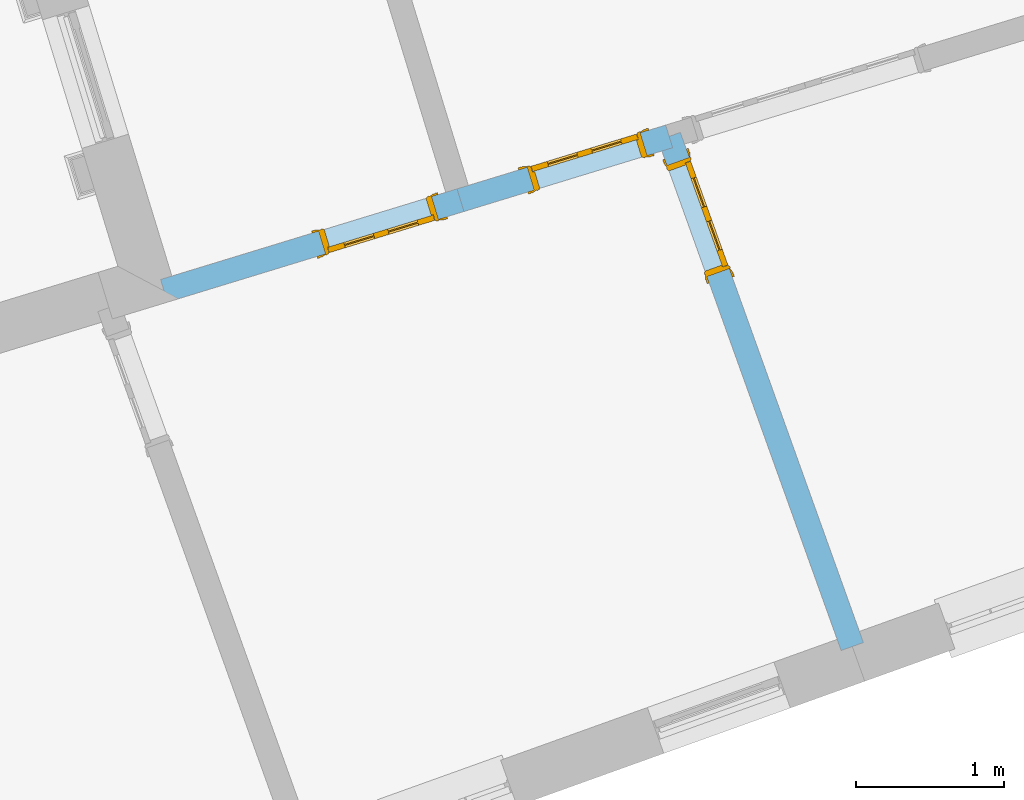
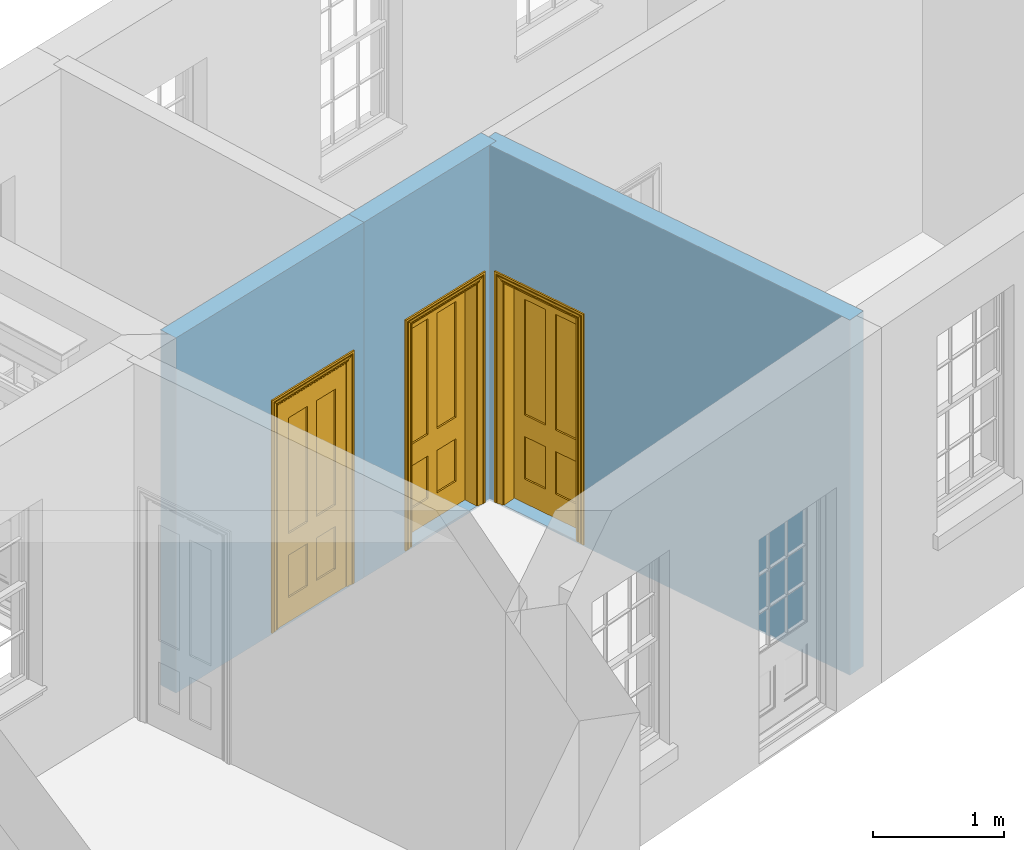
# One storey, part 7 of 10: 3 doors, 3 openings, plus 3 elements that do not belong to this part.
"""IFC2X3 building model written with IfcOpenShell, lengths in metres."""

from ifc_helpers import new_model, si_unit, frame, origin, place, context, subcontext, project, spatial, polyline, outline, extrude, faceted_brep, material, layer, layer_set, layer_usage, element, fill, save


model = new_model("IFC2X3")

# Units and contexts
model_context = context("Model", 3, world=origin())
body_context = subcontext(model_context, "Body", "Model", "MODEL_VIEW")
ifc_project = project(units=[si_unit("PLANEANGLEUNIT", "RADIAN"), si_unit("MASSUNIT", "GRAM", prefix="KILO"), si_unit("FORCEUNIT", "NEWTON", prefix="KILO"), si_unit("LENGTHUNIT", "METRE")], contexts=[model_context])

# Site, building, storey
site_placement = place(None, origin())
site = spatial("IfcSite", under=ifc_project, at=site_placement, CompositionType="ELEMENT")
building_placement = place(None, origin())
building = spatial("IfcBuilding", under=site, at=building_placement, Name="Building plot-9", CompositionType="ELEMENT")
storey_placement = place(None, frame((0.0, 0.0, 1.0)))
storey = spatial("IfcBuildingStorey", under=building, at=storey_placement, Name="Floor 0", CompositionType="ELEMENT", Elevation=1.0)

# Wall, opening, door
ifc_material = material(Name="Masonry")
ifc_layer = layer(ifc_material, 0.16, ventilated=False)
ifc_layer_set = layer_set([ifc_layer], Name="My Wall")
ifc_layer_usage = layer_usage(ifc_layer_set, "AXIS2", "NEGATIVE", 0.08)
wall_1_placement = place(storey_placement, origin())
wall_1 = element("IfcWallStandardCase", 1, at=wall_1_placement, inside=storey, material=ifc_layer_usage, Name="interior", context=body_context, shape_type="SweptSolid", body=[
    extrude(outline(polyline([(34.9703397464498, 18.7852880833866), (34.9235636395364, 18.9382978733414), (32.9172202067024, 18.3249453882046), (32.9639963136158, 18.1719355982498), (34.9703397464498, 18.7852880833866)])), origin(), (0.0, 0.0, 1.0), 3.3),
])
opening_1_placement = place(storey_placement, frame((0.0, 0.0, 0.02)))
opening_1 = element("IfcOpeningElement", 2, at=opening_1_placement, cuts=wall_1, Name="Opening", ObjectType="Opening", context=body_context, shape_type="SweptSolid", body=[
    extrude(outline(polyline([(34.7514276258372, 18.885674753064), (33.9863786760629, 18.6517942184974), (34.0331547829762, 18.4987844285425), (34.7982037327505, 18.7326649631091), (34.7514276258372, 18.885674753064)])), origin(), (0.0, 0.0, 1.0), 2.1),
])
door_1_placement = place(storey_placement, frame((34.7748156792939, 18.8091698580865, 0.02), z_axis=(0.0, 0.0, 1.0), x_axis=(-0.765048949774354, -0.233880534566598, 0.0)))
door_1 = element("IfcDoor", 3, at=door_1_placement, inside=storey, Name="circulation inside door", OverallHeight=2.1, OverallWidth=0.8, context=body_context, shape_type="Brep", held_by="IfcProductRepresentation", body=[
    faceted_brep([(0.773, 0.08, 1.895), (0.66, 0.08, 1.895), (0.66, 0.08, 2.073), (0.773, 0.08, 2.073), (0.773, 0.08, 0.82), (0.66, 0.08, 0.82), (0.45, 0.08, 1.895), (0.45, 0.08, 2.073), (0.773, 0.08, 0.62), (0.66, 0.08, 0.62), (0.66, 0.065, 0.82), (0.66, 0.065, 1.895), (0.45, 0.065, 1.895), (0.35, 0.08, 1.895), (0.35, 0.08, 2.073), (0.773, 0.08, 0.225), (0.66, 0.08, 0.225), (0.45, 0.08, 0.62), (0.45, 0.08, 0.82), (0.45, 0.065, 0.82), (0.35, 0.08, 0.82), (0.14, 0.08, 2.073), (0.14, 0.08, 1.895), (0.773, 0.08, 0.0), (0.66, 0.08, 0.0), (0.66, 0.065, 0.225), (0.66, 0.065, 0.62), (0.45, 0.065, 0.62), (0.35, 0.08, 0.62), (0.35, 0.065, 0.82), (0.35, 0.065, 1.895), (0.14, 0.065, 1.895), (0.027, 0.08, 2.073), (0.027, 0.08, 1.895), (0.773, 0.042, 0.0), (0.66, 0.042, 0.0), (0.45, 0.08, 0.0), (0.45, 0.08, 0.225), (0.45, 0.065, 0.225), (0.35, 0.08, 0.225), (0.14, 0.08, 0.82), (0.14, 0.08, 0.62), (0.14, 0.065, 0.82), (0.027, 0.08, 0.82), (0.773, 0.042, 0.225), (0.66, 0.042, 0.225), (0.45, 0.042, 0.0), (0.35, 0.08, 0.0), (0.35, 0.065, 0.225), (0.35, 0.065, 0.62), (0.14, 0.065, 0.62), (0.027, 0.08, 0.62), (0.773, 0.042, 0.62), (0.66, 0.042, 0.62), (0.45, 0.042, 0.225), (0.35, 0.042, 0.0), (0.14, 0.08, 0.225), (0.14, 0.08, 0.0), (0.14, 0.065, 0.225), (0.027, 0.08, 0.225), (0.773, 0.042, 0.82), (0.66, 0.042, 0.82), (0.66, 0.057, 0.62), (0.66, 0.057, 0.225), (0.45, 0.057, 0.225), (0.35, 0.042, 0.225), (0.14, 0.042, 0.0), (0.027, 0.08, 0.0), (0.773, 0.042, 1.895), (0.66, 0.042, 1.895), (0.45, 0.042, 0.62), (0.45, 0.042, 0.82), (0.45, 0.057, 0.62), (0.35, 0.042, 0.62), (0.14, 0.042, 0.225), (0.027, 0.042, 0.0), (0.773, 0.042, 2.073), (0.66, 0.042, 2.073), (0.66, 0.057, 1.895), (0.66, 0.057, 0.82), (0.45, 0.057, 0.82), (0.35, 0.042, 0.82), (0.35, 0.057, 0.62), (0.35, 0.057, 0.225), (0.14, 0.057, 0.225), (0.027, 0.042, 0.225), (0.45, 0.042, 1.895), (0.45, 0.042, 2.073), (0.45, 0.057, 1.895), (0.35, 0.042, 1.895), (0.14, 0.042, 0.82), (0.14, 0.042, 0.62), (0.14, 0.057, 0.62), (0.027, 0.042, 0.62), (0.35, 0.042, 2.073), (0.35, 0.057, 1.895), (0.35, 0.057, 0.82), (0.14, 0.057, 0.82), (0.027, 0.042, 0.82), (0.14, 0.042, 2.073), (0.14, 0.042, 1.895), (0.14, 0.057, 1.895), (0.027, 0.042, 1.895), (0.027, 0.042, 2.073), (0.02, 0.085, 0.0), (0.005, 0.09, 0.0), (0.005, 0.09, 2.095), (0.02, 0.085, 2.08), (0.02, 0.08, 0.0), (0.0, 0.085, 0.0), (0.0, 0.085, 2.1), (0.795, 0.09, 2.095), (0.78, 0.085, 2.08), (0.02, 0.08, 2.08), (0.0, 0.08, 0.0), (-0.032, 0.095, 0.0), (-0.032, 0.095, 2.132), (0.8, 0.085, 2.1), (0.795, 0.09, 0.0), (0.78, 0.085, 0.0), (0.78, 0.08, 2.08), (0.04, 0.04, 0.0), (0.025, 0.04, 0.0), (0.025, 0.04, 2.075), (0.04, 0.04, 2.06), (-0.04, 0.09, 0.0), (-0.04, 0.09, 2.14), (0.832, 0.095, 2.132), (0.8, 0.085, 0.0), (0.78, 0.08, 0.0), (0.8, 0.08, 0.0), (0.86, 0.08, 0.0), (0.86, 0.08, 2.16), (0.8, 0.08, 2.1), (-0.06, 0.08, 2.16), (0.0, 0.08, 2.1), (-0.06, 0.08, 0.0), (-0.04, 0.095, 0.0), (-0.04, 0.095, 2.14), (0.84, 0.09, 2.14), (0.832, 0.095, 0.0), (0.84, 0.09, 0.0), (0.86, 0.095, 0.0), (0.86, 0.095, 2.16), (-0.06, 0.095, 2.16), (-0.06, 0.095, 0.0), (0.84, 0.095, 0.0), (0.84, 0.095, 2.14), (-0.025, -0.095, 0.0), (-0.025, -0.09, 0.0), (-0.025, -0.09, 2.125), (-0.025, -0.095, 2.125), (-0.017, -0.095, 0.0), (-0.017, -0.095, 2.117), (0.825, -0.09, 2.125), (0.825, -0.095, 2.125), (0.825, -0.095, 0.0), (0.845, -0.095, 0.0), (-0.045, -0.095, 2.145), (-0.045, -0.095, 0.0), (0.845, -0.095, 2.145), (0.015, -0.085, 0.0), (0.015, -0.085, 2.085), (0.817, -0.095, 2.117), (0.825, -0.09, 0.0), (0.845, -0.08, 0.0), (0.845, -0.08, 2.145), (-0.045, -0.08, 2.145), (-0.045, -0.08, 0.0), (0.02, -0.09, 0.0), (0.02, -0.09, 2.08), (0.785, -0.085, 2.085), (0.817, -0.095, 0.0), (0.8, -0.08, 0.0), (0.8, -0.08, 2.1), (0.0, -0.08, 2.1), (0.0, -0.08, 0.0), (0.035, -0.085, 0.0), (0.035, -0.085, 2.065), (0.78, -0.09, 2.08), (0.785, -0.085, 0.0), (0.775, 0.04, 2.075), (0.76, 0.04, 2.06), (0.035, -0.08, 2.065), (0.035, -0.08, 0.0), (0.765, -0.085, 2.065), (0.78, -0.09, 0.0), (0.765, -0.08, 0.0), (0.765, -0.08, 2.065), (0.765, -0.085, 0.0), (0.04, -0.08, 2.06), (0.04, -0.08, 0.0), (0.76, -0.08, 2.06), (0.76, -0.08, 0.0), (0.76, 0.04, 0.0), (0.775, 0.04, 0.0), (0.025, 0.08, 0.0), (0.025, 0.08, 2.075), (0.775, 0.08, 0.0), (0.775, 0.08, 2.075)], [[[0, 1, 2, 3]], [[1, 0, 4, 5]], [[1, 6, 7, 2]], [[8, 9, 5, 4]], [[1, 5, 10, 11]], [[6, 1, 11, 12]], [[6, 13, 14, 7]], [[15, 16, 9, 8]], [[9, 17, 18, 5]], [[5, 18, 19, 10]], [[10, 19, 12, 11]], [[18, 6, 12, 19]], [[18, 20, 13, 6]], [[21, 14, 13, 22]], [[23, 24, 16, 15]], [[9, 16, 25, 26]], [[17, 9, 26, 27]], [[17, 28, 20, 18]], [[13, 20, 29, 30]], [[22, 13, 30, 31]], [[32, 21, 22, 33]], [[34, 35, 24, 23]], [[24, 36, 37, 16]], [[16, 37, 38, 25]], [[25, 38, 27, 26]], [[37, 17, 27, 38]], [[37, 39, 28, 17]], [[40, 20, 28, 41]], [[20, 40, 42, 29]], [[31, 30, 29, 42]], [[40, 22, 31, 42]], [[33, 22, 40, 43]], [[35, 34, 44, 45]], [[35, 46, 36, 24]], [[36, 47, 39, 37]], [[28, 39, 48, 49]], [[41, 28, 49, 50]], [[43, 40, 41, 51]], [[45, 44, 52, 53]], [[46, 35, 45, 54]], [[46, 55, 47, 36]], [[56, 39, 47, 57]], [[39, 56, 58, 48]], [[50, 49, 48, 58]], [[56, 41, 50, 58]], [[51, 41, 56, 59]], [[53, 52, 60, 61]], [[45, 53, 62, 63]], [[54, 45, 63, 64]], [[55, 46, 54, 65]], [[55, 66, 57, 47]], [[59, 56, 57, 67]], [[61, 60, 68, 69]], [[70, 53, 61, 71]], [[53, 70, 72, 62]], [[72, 64, 63, 62]], [[70, 54, 64, 72]], [[65, 54, 70, 73]], [[65, 74, 66, 55]], [[67, 57, 66, 75]], [[69, 68, 76, 77]], [[61, 69, 78, 79]], [[71, 61, 79, 80]], [[73, 70, 71, 81]], [[65, 73, 82, 83]], [[74, 65, 83, 84]], [[74, 85, 75, 66]], [[86, 69, 77, 87]], [[69, 86, 88, 78]], [[88, 80, 79, 78]], [[86, 71, 80, 88]], [[81, 71, 86, 89]], [[73, 81, 90, 91]], [[73, 91, 92, 82]], [[83, 82, 92, 84]], [[91, 74, 84, 92]], [[91, 93, 85, 74]], [[89, 86, 87, 94]], [[81, 89, 95, 96]], [[90, 81, 96, 97]], [[90, 98, 93, 91]], [[94, 99, 100, 89]], [[89, 100, 101, 95]], [[101, 97, 96, 95]], [[100, 90, 97, 101]], [[100, 102, 98, 90]], [[99, 103, 102, 100]], [[32, 103, 99, 21]], [[102, 103, 32, 33]], [[98, 102, 33, 43]], [[21, 99, 94, 14]], [[94, 87, 7, 14]], [[7, 87, 77, 2]], [[76, 3, 2, 77]], [[43, 51, 93, 98]], [[51, 59, 85, 93]], [[67, 75, 85, 59]], [[34, 23, 15, 44]], [[44, 15, 8, 52]], [[52, 8, 4, 60]], [[0, 68, 60, 4]], [[0, 3, 76, 68]], [[104, 105, 106, 107]], [[104, 108, 109, 105]], [[105, 109, 110, 106]], [[107, 106, 111, 112]], [[107, 113, 108, 104]], [[114, 109, 108]], [[109, 115, 116, 110]], [[106, 110, 117, 111]], [[112, 111, 118, 119]], [[113, 107, 112, 120]], [[121, 122, 123, 124]], [[115, 109, 114, 125]], [[115, 125, 126, 116]], [[110, 116, 127, 117]], [[111, 117, 128, 118]], [[118, 128, 129, 119]], [[120, 112, 119, 129]], [[130, 129, 128]], [[130, 131, 132, 133]], [[133, 132, 134, 135]], [[135, 134, 136, 114]], [[136, 125, 114]], [[125, 137, 138, 126]], [[116, 126, 139, 127]], [[117, 127, 140, 128]], [[141, 130, 128, 140]], [[131, 130, 141]], [[131, 142, 143, 132]], [[132, 143, 144, 134]], [[134, 144, 145, 136]], [[137, 125, 136, 145]], [[143, 142, 146]], [[143, 146, 147]], [[137, 145, 144]], [[143, 147, 138]], [[138, 137, 144]], [[143, 138, 144]], [[126, 138, 147, 139]], [[127, 139, 141, 140]], [[142, 131, 141, 146]], [[139, 147, 146, 141]], [[148, 149, 150, 151]], [[149, 152, 153, 150]], [[151, 150, 154, 155]], [[155, 156, 157]], [[158, 159, 148]], [[158, 148, 151]], [[155, 157, 160]], [[158, 151, 155]], [[155, 160, 158]], [[152, 161, 162, 153]], [[150, 153, 163, 154]], [[155, 154, 164, 156]], [[156, 164, 165, 157]], [[157, 165, 166, 160]], [[160, 166, 167, 158]], [[158, 167, 168, 159]], [[161, 169, 170, 162]], [[153, 162, 171, 163]], [[154, 163, 172, 164]], [[165, 164, 173]], [[165, 173, 174, 166]], [[166, 174, 175, 167]], [[167, 175, 176, 168]], [[169, 177, 178, 170]], [[162, 170, 179, 171]], [[163, 171, 180, 172]], [[172, 180, 173, 164]], [[124, 123, 181, 182]], [[183, 178, 177, 184]], [[170, 178, 185, 179]], [[171, 179, 186, 180]], [[187, 173, 180]], [[185, 188, 187, 189]], [[188, 185, 178, 183]], [[179, 185, 189, 186]], [[189, 187, 180, 186]], [[190, 183, 184, 191]], [[192, 188, 183, 190]], [[191, 184, 122, 121]], [[124, 190, 191, 121]], [[193, 187, 188, 192]], [[182, 192, 190, 124]], [[184, 176, 122]], [[194, 195, 187, 193]], [[192, 182, 194, 193]], [[161, 176, 184]], [[114, 108, 122, 176]], [[173, 187, 195]], [[152, 149, 176, 161]], [[169, 161, 184, 177]], [[196, 122, 108]], [[176, 175, 135, 114]], [[173, 195, 129, 130]], [[176, 149, 168]], [[123, 122, 196, 197]], [[196, 108, 113, 197]], [[175, 174, 133, 135]], [[198, 129, 195]], [[133, 174, 173, 130]], [[159, 168, 149, 148]], [[181, 123, 197, 199]], [[197, 113, 120, 199]], [[199, 120, 129, 198]], [[195, 181, 199, 198]], [[195, 194, 182, 181]]]),
])
fill(opening_1, door_1)

wall_2_placement = place(storey_placement, origin())
wall_2 = element("IfcWallStandardCase", 4, at=wall_2_placement, inside=storey, material=ifc_layer_usage, Name="interior", context=body_context, shape_type="SweptSolid", body=[
    extrude(outline(polyline([(34.9235636395364, 18.9382978733414), (34.9703397464498, 18.7852880833866), (36.3823365784182, 19.2169448734057), (36.3355604715048, 19.3699546633605), (34.9235636395364, 18.9382978733414)])), origin(), (0.0, 0.0, 1.0), 3.3),
])
opening_2_placement = place(storey_placement, frame((0.0, 0.0, 0.02)))
opening_2 = element("IfcOpeningElement", 5, at=opening_2_placement, cuts=wall_2, Name="Opening", ObjectType="Opening", context=body_context, shape_type="SweptSolid", body=[
    extrude(outline(polyline([(35.4451516149446, 18.9304412185616), (36.2102005647189, 19.1643217531282), (36.1634244578056, 19.3173315430831), (35.3983755080313, 19.0834510085165), (35.4451516149446, 18.9304412185616)])), origin(), (0.0, 0.0, 1.0), 2.1),
])
door_2_placement = place(storey_placement, frame((35.4217635614879, 19.006946113539, 0.02), z_axis=(0.0, 0.0, 1.0), x_axis=(0.765048949774361, 0.233880534566577, 0.0)))
door_2 = element("IfcDoor", 6, at=door_2_placement, inside=storey, Name="living inside door", OverallHeight=2.1, OverallWidth=0.8, context=body_context, shape_type="Brep", held_by="IfcProductRepresentation", body=[
    faceted_brep([(0.773, 0.08, 1.895), (0.66, 0.08, 1.895), (0.66, 0.08, 2.073), (0.773, 0.08, 2.073), (0.773, 0.08, 0.82), (0.66, 0.08, 0.82), (0.45, 0.08, 1.895), (0.45, 0.08, 2.073), (0.773, 0.08, 0.62), (0.66, 0.08, 0.62), (0.66, 0.065, 0.82), (0.66, 0.065, 1.895), (0.45, 0.065, 1.895), (0.35, 0.08, 1.895), (0.35, 0.08, 2.073), (0.773, 0.08, 0.225), (0.66, 0.08, 0.225), (0.45, 0.08, 0.62), (0.45, 0.08, 0.82), (0.45, 0.065, 0.82), (0.35, 0.08, 0.82), (0.14, 0.08, 2.073), (0.14, 0.08, 1.895), (0.773, 0.08, 0.0), (0.66, 0.08, 0.0), (0.66, 0.065, 0.225), (0.66, 0.065, 0.62), (0.45, 0.065, 0.62), (0.35, 0.08, 0.62), (0.35, 0.065, 0.82), (0.35, 0.065, 1.895), (0.14, 0.065, 1.895), (0.027, 0.08, 2.073), (0.027, 0.08, 1.895), (0.773, 0.042, 0.0), (0.66, 0.042, 0.0), (0.45, 0.08, 0.0), (0.45, 0.08, 0.225), (0.45, 0.065, 0.225), (0.35, 0.08, 0.225), (0.14, 0.08, 0.82), (0.14, 0.08, 0.62), (0.14, 0.065, 0.82), (0.027, 0.08, 0.82), (0.773, 0.042, 0.225), (0.66, 0.042, 0.225), (0.45, 0.042, 0.0), (0.35, 0.08, 0.0), (0.35, 0.065, 0.225), (0.35, 0.065, 0.62), (0.14, 0.065, 0.62), (0.027, 0.08, 0.62), (0.773, 0.042, 0.62), (0.66, 0.042, 0.62), (0.45, 0.042, 0.225), (0.35, 0.042, 0.0), (0.14, 0.08, 0.225), (0.14, 0.08, 0.0), (0.14, 0.065, 0.225), (0.027, 0.08, 0.225), (0.773, 0.042, 0.82), (0.66, 0.042, 0.82), (0.66, 0.057, 0.62), (0.66, 0.057, 0.225), (0.45, 0.057, 0.225), (0.35, 0.042, 0.225), (0.14, 0.042, 0.0), (0.027, 0.08, 0.0), (0.773, 0.042, 1.895), (0.66, 0.042, 1.895), (0.45, 0.042, 0.62), (0.45, 0.042, 0.82), (0.45, 0.057, 0.62), (0.35, 0.042, 0.62), (0.14, 0.042, 0.225), (0.027, 0.042, 0.0), (0.773, 0.042, 2.073), (0.66, 0.042, 2.073), (0.66, 0.057, 1.895), (0.66, 0.057, 0.82), (0.45, 0.057, 0.82), (0.35, 0.042, 0.82), (0.35, 0.057, 0.62), (0.35, 0.057, 0.225), (0.14, 0.057, 0.225), (0.027, 0.042, 0.225), (0.45, 0.042, 1.895), (0.45, 0.042, 2.073), (0.45, 0.057, 1.895), (0.35, 0.042, 1.895), (0.14, 0.042, 0.82), (0.14, 0.042, 0.62), (0.14, 0.057, 0.62), (0.027, 0.042, 0.62), (0.35, 0.042, 2.073), (0.35, 0.057, 1.895), (0.35, 0.057, 0.82), (0.14, 0.057, 0.82), (0.027, 0.042, 0.82), (0.14, 0.042, 2.073), (0.14, 0.042, 1.895), (0.14, 0.057, 1.895), (0.027, 0.042, 1.895), (0.027, 0.042, 2.073), (0.02, 0.085, 0.0), (0.005, 0.09, 0.0), (0.005, 0.09, 2.095), (0.02, 0.085, 2.08), (0.02, 0.08, 0.0), (0.0, 0.085, 0.0), (0.0, 0.085, 2.1), (0.795, 0.09, 2.095), (0.78, 0.085, 2.08), (0.02, 0.08, 2.08), (0.0, 0.08, 0.0), (-0.032, 0.095, 0.0), (-0.032, 0.095, 2.132), (0.8, 0.085, 2.1), (0.795, 0.09, 0.0), (0.78, 0.085, 0.0), (0.78, 0.08, 2.08), (0.04, 0.04, 0.0), (0.025, 0.04, 0.0), (0.025, 0.04, 2.075), (0.04, 0.04, 2.06), (-0.04, 0.09, 0.0), (-0.04, 0.09, 2.14), (0.832, 0.095, 2.132), (0.8, 0.085, 0.0), (0.78, 0.08, 0.0), (0.8, 0.08, 0.0), (0.86, 0.08, 0.0), (0.86, 0.08, 2.16), (0.8, 0.08, 2.1), (-0.06, 0.08, 2.16), (0.0, 0.08, 2.1), (-0.06, 0.08, 0.0), (-0.04, 0.095, 0.0), (-0.04, 0.095, 2.14), (0.84, 0.09, 2.14), (0.832, 0.095, 0.0), (0.84, 0.09, 0.0), (0.86, 0.095, 0.0), (0.86, 0.095, 2.16), (-0.06, 0.095, 2.16), (-0.06, 0.095, 0.0), (0.84, 0.095, 0.0), (0.84, 0.095, 2.14), (-0.025, -0.095, 0.0), (-0.025, -0.09, 0.0), (-0.025, -0.09, 2.125), (-0.025, -0.095, 2.125), (-0.017, -0.095, 0.0), (-0.017, -0.095, 2.117), (0.825, -0.09, 2.125), (0.825, -0.095, 2.125), (0.825, -0.095, 0.0), (0.845, -0.095, 0.0), (-0.045, -0.095, 2.145), (-0.045, -0.095, 0.0), (0.845, -0.095, 2.145), (0.015, -0.085, 0.0), (0.015, -0.085, 2.085), (0.817, -0.095, 2.117), (0.825, -0.09, 0.0), (0.845, -0.08, 0.0), (0.845, -0.08, 2.145), (-0.045, -0.08, 2.145), (-0.045, -0.08, 0.0), (0.02, -0.09, 0.0), (0.02, -0.09, 2.08), (0.785, -0.085, 2.085), (0.817, -0.095, 0.0), (0.8, -0.08, 0.0), (0.8, -0.08, 2.1), (0.0, -0.08, 2.1), (0.0, -0.08, 0.0), (0.035, -0.085, 0.0), (0.035, -0.085, 2.065), (0.78, -0.09, 2.08), (0.785, -0.085, 0.0), (0.775, 0.04, 2.075), (0.76, 0.04, 2.06), (0.035, -0.08, 2.065), (0.035, -0.08, 0.0), (0.765, -0.085, 2.065), (0.78, -0.09, 0.0), (0.765, -0.08, 0.0), (0.765, -0.08, 2.065), (0.765, -0.085, 0.0), (0.04, -0.08, 2.06), (0.04, -0.08, 0.0), (0.76, -0.08, 2.06), (0.76, -0.08, 0.0), (0.76, 0.04, 0.0), (0.775, 0.04, 0.0), (0.025, 0.08, 0.0), (0.025, 0.08, 2.075), (0.775, 0.08, 0.0), (0.775, 0.08, 2.075)], [[[0, 1, 2, 3]], [[1, 0, 4, 5]], [[1, 6, 7, 2]], [[8, 9, 5, 4]], [[1, 5, 10, 11]], [[6, 1, 11, 12]], [[6, 13, 14, 7]], [[15, 16, 9, 8]], [[9, 17, 18, 5]], [[5, 18, 19, 10]], [[10, 19, 12, 11]], [[18, 6, 12, 19]], [[18, 20, 13, 6]], [[21, 14, 13, 22]], [[23, 24, 16, 15]], [[9, 16, 25, 26]], [[17, 9, 26, 27]], [[17, 28, 20, 18]], [[13, 20, 29, 30]], [[22, 13, 30, 31]], [[32, 21, 22, 33]], [[34, 35, 24, 23]], [[24, 36, 37, 16]], [[16, 37, 38, 25]], [[25, 38, 27, 26]], [[37, 17, 27, 38]], [[37, 39, 28, 17]], [[40, 20, 28, 41]], [[20, 40, 42, 29]], [[31, 30, 29, 42]], [[40, 22, 31, 42]], [[33, 22, 40, 43]], [[35, 34, 44, 45]], [[35, 46, 36, 24]], [[36, 47, 39, 37]], [[28, 39, 48, 49]], [[41, 28, 49, 50]], [[43, 40, 41, 51]], [[45, 44, 52, 53]], [[46, 35, 45, 54]], [[46, 55, 47, 36]], [[56, 39, 47, 57]], [[39, 56, 58, 48]], [[50, 49, 48, 58]], [[56, 41, 50, 58]], [[51, 41, 56, 59]], [[53, 52, 60, 61]], [[45, 53, 62, 63]], [[54, 45, 63, 64]], [[55, 46, 54, 65]], [[55, 66, 57, 47]], [[59, 56, 57, 67]], [[61, 60, 68, 69]], [[70, 53, 61, 71]], [[53, 70, 72, 62]], [[72, 64, 63, 62]], [[70, 54, 64, 72]], [[65, 54, 70, 73]], [[65, 74, 66, 55]], [[67, 57, 66, 75]], [[69, 68, 76, 77]], [[61, 69, 78, 79]], [[71, 61, 79, 80]], [[73, 70, 71, 81]], [[65, 73, 82, 83]], [[74, 65, 83, 84]], [[74, 85, 75, 66]], [[86, 69, 77, 87]], [[69, 86, 88, 78]], [[88, 80, 79, 78]], [[86, 71, 80, 88]], [[81, 71, 86, 89]], [[73, 81, 90, 91]], [[73, 91, 92, 82]], [[83, 82, 92, 84]], [[91, 74, 84, 92]], [[91, 93, 85, 74]], [[89, 86, 87, 94]], [[81, 89, 95, 96]], [[90, 81, 96, 97]], [[90, 98, 93, 91]], [[94, 99, 100, 89]], [[89, 100, 101, 95]], [[101, 97, 96, 95]], [[100, 90, 97, 101]], [[100, 102, 98, 90]], [[99, 103, 102, 100]], [[32, 103, 99, 21]], [[102, 103, 32, 33]], [[98, 102, 33, 43]], [[21, 99, 94, 14]], [[94, 87, 7, 14]], [[7, 87, 77, 2]], [[76, 3, 2, 77]], [[43, 51, 93, 98]], [[51, 59, 85, 93]], [[67, 75, 85, 59]], [[34, 23, 15, 44]], [[44, 15, 8, 52]], [[52, 8, 4, 60]], [[0, 68, 60, 4]], [[0, 3, 76, 68]], [[104, 105, 106, 107]], [[104, 108, 109, 105]], [[105, 109, 110, 106]], [[107, 106, 111, 112]], [[107, 113, 108, 104]], [[114, 109, 108]], [[109, 115, 116, 110]], [[106, 110, 117, 111]], [[112, 111, 118, 119]], [[113, 107, 112, 120]], [[121, 122, 123, 124]], [[115, 109, 114, 125]], [[115, 125, 126, 116]], [[110, 116, 127, 117]], [[111, 117, 128, 118]], [[118, 128, 129, 119]], [[120, 112, 119, 129]], [[130, 129, 128]], [[130, 131, 132, 133]], [[133, 132, 134, 135]], [[135, 134, 136, 114]], [[136, 125, 114]], [[125, 137, 138, 126]], [[116, 126, 139, 127]], [[117, 127, 140, 128]], [[141, 130, 128, 140]], [[131, 130, 141]], [[131, 142, 143, 132]], [[132, 143, 144, 134]], [[134, 144, 145, 136]], [[137, 125, 136, 145]], [[143, 142, 146]], [[143, 146, 147]], [[137, 145, 144]], [[143, 147, 138]], [[138, 137, 144]], [[143, 138, 144]], [[126, 138, 147, 139]], [[127, 139, 141, 140]], [[142, 131, 141, 146]], [[139, 147, 146, 141]], [[148, 149, 150, 151]], [[149, 152, 153, 150]], [[151, 150, 154, 155]], [[155, 156, 157]], [[158, 159, 148]], [[158, 148, 151]], [[155, 157, 160]], [[158, 151, 155]], [[155, 160, 158]], [[152, 161, 162, 153]], [[150, 153, 163, 154]], [[155, 154, 164, 156]], [[156, 164, 165, 157]], [[157, 165, 166, 160]], [[160, 166, 167, 158]], [[158, 167, 168, 159]], [[161, 169, 170, 162]], [[153, 162, 171, 163]], [[154, 163, 172, 164]], [[165, 164, 173]], [[165, 173, 174, 166]], [[166, 174, 175, 167]], [[167, 175, 176, 168]], [[169, 177, 178, 170]], [[162, 170, 179, 171]], [[163, 171, 180, 172]], [[172, 180, 173, 164]], [[124, 123, 181, 182]], [[183, 178, 177, 184]], [[170, 178, 185, 179]], [[171, 179, 186, 180]], [[187, 173, 180]], [[185, 188, 187, 189]], [[188, 185, 178, 183]], [[179, 185, 189, 186]], [[189, 187, 180, 186]], [[190, 183, 184, 191]], [[192, 188, 183, 190]], [[191, 184, 122, 121]], [[124, 190, 191, 121]], [[193, 187, 188, 192]], [[182, 192, 190, 124]], [[184, 176, 122]], [[194, 195, 187, 193]], [[192, 182, 194, 193]], [[161, 176, 184]], [[114, 108, 122, 176]], [[173, 187, 195]], [[152, 149, 176, 161]], [[169, 161, 184, 177]], [[196, 122, 108]], [[176, 175, 135, 114]], [[173, 195, 129, 130]], [[176, 149, 168]], [[123, 122, 196, 197]], [[196, 108, 113, 197]], [[175, 174, 133, 135]], [[198, 129, 195]], [[133, 174, 173, 130]], [[159, 168, 149, 148]], [[181, 123, 197, 199]], [[197, 113, 120, 199]], [[199, 120, 129, 198]], [[195, 181, 199, 198]], [[195, 194, 182, 181]]]),
])
fill(opening_2, door_2)

wall_3_placement = place(storey_placement, origin())
wall_3 = element("IfcWallStandardCase", 7, at=wall_3_placement, inside=storey, material=ifc_layer_usage, Name="interior", context=body_context, shape_type="SweptSolid", body=[
    extrude(outline(polyline([(36.4342442893172, 19.3204784174447), (36.2836527606058, 19.2664211193215), (37.5228374656723, 15.8143299943324), (37.6734289943837, 15.8683872924556), (36.4342442893172, 19.3204784174447)])), origin(), (0.0, 0.0, 1.0), 3.3),
])
opening_3_placement = place(storey_placement, frame((0.0, 0.0, 0.02)))
opening_3 = element("IfcOpeningElement", 8, at=opening_3_placement, cuts=wall_3, Name="Opening", ObjectType="Opening", context=body_context, shape_type="SweptSolid", body=[
    extrude(outline(polyline([(36.3444672209943, 19.0970056495212), (36.6147537116099, 18.3440480059644), (36.7653452403213, 18.3981053040875), (36.4950587497057, 19.1510629476444), (36.3444672209943, 19.0970056495212)])), origin(), (0.0, 0.0, 1.0), 2.1),
])
door_3_placement = place(storey_placement, frame((36.41976298535, 19.1240342985828, 0.02), z_axis=(0.0, 0.0, 1.0), x_axis=(0.270286490615604, -0.752957643556858, 0.0)))
door_3 = element("IfcDoor", 9, at=door_3_placement, inside=storey, Name="kitchen inside door", OverallHeight=2.1, OverallWidth=0.8, context=body_context, shape_type="Brep", held_by="IfcProductRepresentation", body=[
    faceted_brep([(0.773, 0.08, 1.895), (0.66, 0.08, 1.895), (0.66, 0.08, 2.073), (0.773, 0.08, 2.073), (0.773, 0.08, 0.82), (0.66, 0.08, 0.82), (0.45, 0.08, 1.895), (0.45, 0.08, 2.073), (0.773, 0.08, 0.62), (0.66, 0.08, 0.62), (0.66, 0.065, 0.82), (0.66, 0.065, 1.895), (0.45, 0.065, 1.895), (0.35, 0.08, 1.895), (0.35, 0.08, 2.073), (0.773, 0.08, 0.225), (0.66, 0.08, 0.225), (0.45, 0.08, 0.62), (0.45, 0.08, 0.82), (0.45, 0.065, 0.82), (0.35, 0.08, 0.82), (0.14, 0.08, 2.073), (0.14, 0.08, 1.895), (0.773, 0.08, 0.0), (0.66, 0.08, 0.0), (0.66, 0.065, 0.225), (0.66, 0.065, 0.62), (0.45, 0.065, 0.62), (0.35, 0.08, 0.62), (0.35, 0.065, 0.82), (0.35, 0.065, 1.895), (0.14, 0.065, 1.895), (0.027, 0.08, 2.073), (0.027, 0.08, 1.895), (0.773, 0.042, 0.0), (0.66, 0.042, 0.0), (0.45, 0.08, 0.0), (0.45, 0.08, 0.225), (0.45, 0.065, 0.225), (0.35, 0.08, 0.225), (0.14, 0.08, 0.82), (0.14, 0.08, 0.62), (0.14, 0.065, 0.82), (0.027, 0.08, 0.82), (0.773, 0.042, 0.225), (0.66, 0.042, 0.225), (0.45, 0.042, 0.0), (0.35, 0.08, 0.0), (0.35, 0.065, 0.225), (0.35, 0.065, 0.62), (0.14, 0.065, 0.62), (0.027, 0.08, 0.62), (0.773, 0.042, 0.62), (0.66, 0.042, 0.62), (0.45, 0.042, 0.225), (0.35, 0.042, 0.0), (0.14, 0.08, 0.225), (0.14, 0.08, 0.0), (0.14, 0.065, 0.225), (0.027, 0.08, 0.225), (0.773, 0.042, 0.82), (0.66, 0.042, 0.82), (0.66, 0.057, 0.62), (0.66, 0.057, 0.225), (0.45, 0.057, 0.225), (0.35, 0.042, 0.225), (0.14, 0.042, 0.0), (0.027, 0.08, 0.0), (0.773, 0.042, 1.895), (0.66, 0.042, 1.895), (0.45, 0.042, 0.62), (0.45, 0.042, 0.82), (0.45, 0.057, 0.62), (0.35, 0.042, 0.62), (0.14, 0.042, 0.225), (0.027, 0.042, 0.0), (0.773, 0.042, 2.073), (0.66, 0.042, 2.073), (0.66, 0.057, 1.895), (0.66, 0.057, 0.82), (0.45, 0.057, 0.82), (0.35, 0.042, 0.82), (0.35, 0.057, 0.62), (0.35, 0.057, 0.225), (0.14, 0.057, 0.225), (0.027, 0.042, 0.225), (0.45, 0.042, 1.895), (0.45, 0.042, 2.073), (0.45, 0.057, 1.895), (0.35, 0.042, 1.895), (0.14, 0.042, 0.82), (0.14, 0.042, 0.62), (0.14, 0.057, 0.62), (0.027, 0.042, 0.62), (0.35, 0.042, 2.073), (0.35, 0.057, 1.895), (0.35, 0.057, 0.82), (0.14, 0.057, 0.82), (0.027, 0.042, 0.82), (0.14, 0.042, 2.073), (0.14, 0.042, 1.895), (0.14, 0.057, 1.895), (0.027, 0.042, 1.895), (0.027, 0.042, 2.073), (0.02, 0.085, 0.0), (0.005, 0.09, 0.0), (0.005, 0.09, 2.095), (0.02, 0.085, 2.08), (0.02, 0.08, 0.0), (0.0, 0.085, 0.0), (0.0, 0.085, 2.1), (0.795, 0.09, 2.095), (0.78, 0.085, 2.08), (0.02, 0.08, 2.08), (0.0, 0.08, 0.0), (-0.032, 0.095, 0.0), (-0.032, 0.095, 2.132), (0.8, 0.085, 2.1), (0.795, 0.09, 0.0), (0.78, 0.085, 0.0), (0.78, 0.08, 2.08), (0.04, 0.04, 0.0), (0.025, 0.04, 0.0), (0.025, 0.04, 2.075), (0.04, 0.04, 2.06), (-0.04, 0.09, 0.0), (-0.04, 0.09, 2.14), (0.832, 0.095, 2.132), (0.8, 0.085, 0.0), (0.78, 0.08, 0.0), (0.8, 0.08, 0.0), (0.86, 0.08, 0.0), (0.86, 0.08, 2.16), (0.8, 0.08, 2.1), (-0.06, 0.08, 2.16), (0.0, 0.08, 2.1), (-0.06, 0.08, 0.0), (-0.04, 0.095, 0.0), (-0.04, 0.095, 2.14), (0.84, 0.09, 2.14), (0.832, 0.095, 0.0), (0.84, 0.09, 0.0), (0.86, 0.095, 0.0), (0.86, 0.095, 2.16), (-0.06, 0.095, 2.16), (-0.06, 0.095, 0.0), (0.84, 0.095, 0.0), (0.84, 0.095, 2.14), (-0.025, -0.095, 0.0), (-0.025, -0.09, 0.0), (-0.025, -0.09, 2.125), (-0.025, -0.095, 2.125), (-0.017, -0.095, 0.0), (-0.017, -0.095, 2.117), (0.825, -0.09, 2.125), (0.825, -0.095, 2.125), (0.825, -0.095, 0.0), (0.845, -0.095, 0.0), (-0.045, -0.095, 2.145), (-0.045, -0.095, 0.0), (0.845, -0.095, 2.145), (0.015, -0.085, 0.0), (0.015, -0.085, 2.085), (0.817, -0.095, 2.117), (0.825, -0.09, 0.0), (0.845, -0.08, 0.0), (0.845, -0.08, 2.145), (-0.045, -0.08, 2.145), (-0.045, -0.08, 0.0), (0.02, -0.09, 0.0), (0.02, -0.09, 2.08), (0.785, -0.085, 2.085), (0.817, -0.095, 0.0), (0.8, -0.08, 0.0), (0.8, -0.08, 2.1), (0.0, -0.08, 2.1), (0.0, -0.08, 0.0), (0.035, -0.085, 0.0), (0.035, -0.085, 2.065), (0.78, -0.09, 2.08), (0.785, -0.085, 0.0), (0.775, 0.04, 2.075), (0.76, 0.04, 2.06), (0.035, -0.08, 2.065), (0.035, -0.08, 0.0), (0.765, -0.085, 2.065), (0.78, -0.09, 0.0), (0.765, -0.08, 0.0), (0.765, -0.08, 2.065), (0.765, -0.085, 0.0), (0.04, -0.08, 2.06), (0.04, -0.08, 0.0), (0.76, -0.08, 2.06), (0.76, -0.08, 0.0), (0.76, 0.04, 0.0), (0.775, 0.04, 0.0), (0.025, 0.08, 0.0), (0.025, 0.08, 2.075), (0.775, 0.08, 0.0), (0.775, 0.08, 2.075)], [[[0, 1, 2, 3]], [[1, 0, 4, 5]], [[1, 6, 7, 2]], [[8, 9, 5, 4]], [[1, 5, 10, 11]], [[6, 1, 11, 12]], [[6, 13, 14, 7]], [[15, 16, 9, 8]], [[9, 17, 18, 5]], [[5, 18, 19, 10]], [[10, 19, 12, 11]], [[18, 6, 12, 19]], [[18, 20, 13, 6]], [[21, 14, 13, 22]], [[23, 24, 16, 15]], [[9, 16, 25, 26]], [[17, 9, 26, 27]], [[17, 28, 20, 18]], [[13, 20, 29, 30]], [[22, 13, 30, 31]], [[32, 21, 22, 33]], [[34, 35, 24, 23]], [[24, 36, 37, 16]], [[16, 37, 38, 25]], [[25, 38, 27, 26]], [[37, 17, 27, 38]], [[37, 39, 28, 17]], [[40, 20, 28, 41]], [[20, 40, 42, 29]], [[31, 30, 29, 42]], [[40, 22, 31, 42]], [[33, 22, 40, 43]], [[35, 34, 44, 45]], [[35, 46, 36, 24]], [[36, 47, 39, 37]], [[28, 39, 48, 49]], [[41, 28, 49, 50]], [[43, 40, 41, 51]], [[45, 44, 52, 53]], [[46, 35, 45, 54]], [[46, 55, 47, 36]], [[56, 39, 47, 57]], [[39, 56, 58, 48]], [[50, 49, 48, 58]], [[56, 41, 50, 58]], [[51, 41, 56, 59]], [[53, 52, 60, 61]], [[45, 53, 62, 63]], [[54, 45, 63, 64]], [[55, 46, 54, 65]], [[55, 66, 57, 47]], [[59, 56, 57, 67]], [[61, 60, 68, 69]], [[70, 53, 61, 71]], [[53, 70, 72, 62]], [[72, 64, 63, 62]], [[70, 54, 64, 72]], [[65, 54, 70, 73]], [[65, 74, 66, 55]], [[67, 57, 66, 75]], [[69, 68, 76, 77]], [[61, 69, 78, 79]], [[71, 61, 79, 80]], [[73, 70, 71, 81]], [[65, 73, 82, 83]], [[74, 65, 83, 84]], [[74, 85, 75, 66]], [[86, 69, 77, 87]], [[69, 86, 88, 78]], [[88, 80, 79, 78]], [[86, 71, 80, 88]], [[81, 71, 86, 89]], [[73, 81, 90, 91]], [[73, 91, 92, 82]], [[83, 82, 92, 84]], [[91, 74, 84, 92]], [[91, 93, 85, 74]], [[89, 86, 87, 94]], [[81, 89, 95, 96]], [[90, 81, 96, 97]], [[90, 98, 93, 91]], [[94, 99, 100, 89]], [[89, 100, 101, 95]], [[101, 97, 96, 95]], [[100, 90, 97, 101]], [[100, 102, 98, 90]], [[99, 103, 102, 100]], [[32, 103, 99, 21]], [[102, 103, 32, 33]], [[98, 102, 33, 43]], [[21, 99, 94, 14]], [[94, 87, 7, 14]], [[7, 87, 77, 2]], [[76, 3, 2, 77]], [[43, 51, 93, 98]], [[51, 59, 85, 93]], [[67, 75, 85, 59]], [[34, 23, 15, 44]], [[44, 15, 8, 52]], [[52, 8, 4, 60]], [[0, 68, 60, 4]], [[0, 3, 76, 68]], [[104, 105, 106, 107]], [[104, 108, 109, 105]], [[105, 109, 110, 106]], [[107, 106, 111, 112]], [[107, 113, 108, 104]], [[114, 109, 108]], [[109, 115, 116, 110]], [[106, 110, 117, 111]], [[112, 111, 118, 119]], [[113, 107, 112, 120]], [[121, 122, 123, 124]], [[115, 109, 114, 125]], [[115, 125, 126, 116]], [[110, 116, 127, 117]], [[111, 117, 128, 118]], [[118, 128, 129, 119]], [[120, 112, 119, 129]], [[130, 129, 128]], [[130, 131, 132, 133]], [[133, 132, 134, 135]], [[135, 134, 136, 114]], [[136, 125, 114]], [[125, 137, 138, 126]], [[116, 126, 139, 127]], [[117, 127, 140, 128]], [[141, 130, 128, 140]], [[131, 130, 141]], [[131, 142, 143, 132]], [[132, 143, 144, 134]], [[134, 144, 145, 136]], [[137, 125, 136, 145]], [[143, 142, 146]], [[143, 146, 147]], [[137, 145, 144]], [[143, 147, 138]], [[138, 137, 144]], [[143, 138, 144]], [[126, 138, 147, 139]], [[127, 139, 141, 140]], [[142, 131, 141, 146]], [[139, 147, 146, 141]], [[148, 149, 150, 151]], [[149, 152, 153, 150]], [[151, 150, 154, 155]], [[155, 156, 157]], [[158, 159, 148]], [[158, 148, 151]], [[155, 157, 160]], [[158, 151, 155]], [[155, 160, 158]], [[152, 161, 162, 153]], [[150, 153, 163, 154]], [[155, 154, 164, 156]], [[156, 164, 165, 157]], [[157, 165, 166, 160]], [[160, 166, 167, 158]], [[158, 167, 168, 159]], [[161, 169, 170, 162]], [[153, 162, 171, 163]], [[154, 163, 172, 164]], [[165, 164, 173]], [[165, 173, 174, 166]], [[166, 174, 175, 167]], [[167, 175, 176, 168]], [[169, 177, 178, 170]], [[162, 170, 179, 171]], [[163, 171, 180, 172]], [[172, 180, 173, 164]], [[124, 123, 181, 182]], [[183, 178, 177, 184]], [[170, 178, 185, 179]], [[171, 179, 186, 180]], [[187, 173, 180]], [[185, 188, 187, 189]], [[188, 185, 178, 183]], [[179, 185, 189, 186]], [[189, 187, 180, 186]], [[190, 183, 184, 191]], [[192, 188, 183, 190]], [[191, 184, 122, 121]], [[124, 190, 191, 121]], [[193, 187, 188, 192]], [[182, 192, 190, 124]], [[184, 176, 122]], [[194, 195, 187, 193]], [[192, 182, 194, 193]], [[161, 176, 184]], [[114, 108, 122, 176]], [[173, 187, 195]], [[152, 149, 176, 161]], [[169, 161, 184, 177]], [[196, 122, 108]], [[176, 175, 135, 114]], [[173, 195, 129, 130]], [[176, 149, 168]], [[123, 122, 196, 197]], [[196, 108, 113, 197]], [[175, 174, 133, 135]], [[198, 129, 195]], [[133, 174, 173, 130]], [[159, 168, 149, 148]], [[181, 123, 197, 199]], [[197, 113, 120, 199]], [[199, 120, 129, 198]], [[195, 181, 199, 198]], [[195, 194, 182, 181]]]),
])
fill(opening_3, door_3)

save(model, "model.ifc")
